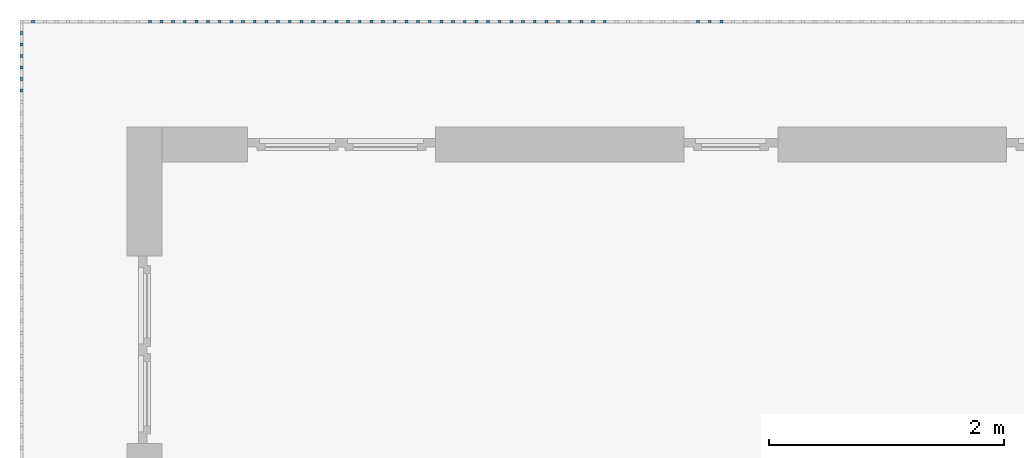
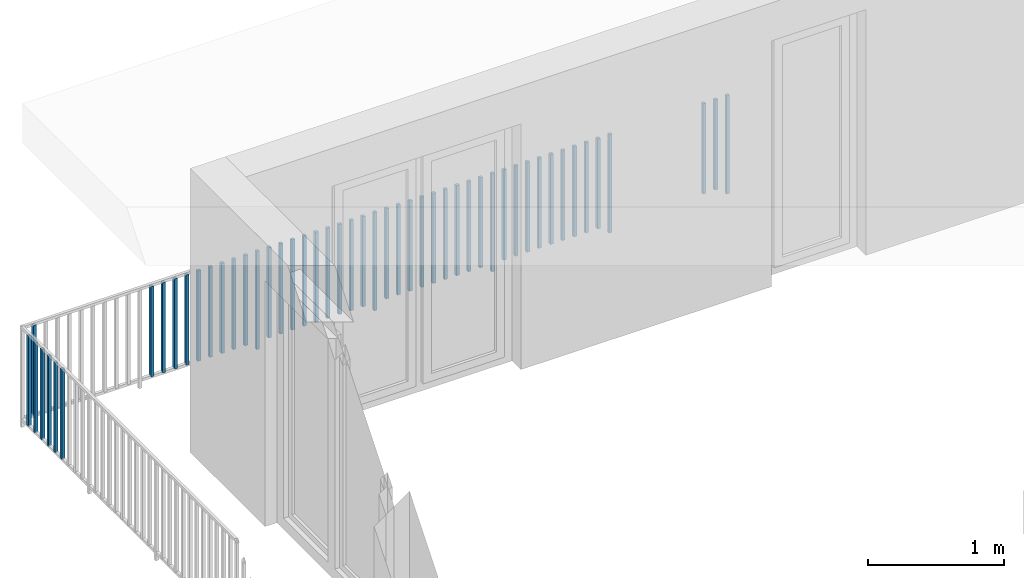
# One storey, part 42 of 48: 50 building element parts, 1 element without a shape of its own.
"""IFC4 building model written with IfcOpenShell, lengths in metres."""

import ifcopenshell
import ifcopenshell.guid

model = None  # the IFC model being written
_history = None  # IfcOwnerHistory: only IFC2X3 demands one
_inside = {}  # id of a spatial element -> (the spatial element, [elements in it])
_under = {}  # id of a project, library or spatial element -> (it, [spatial elements below it])
_declared = {}  # id of a project -> (the project, [libraries it declares])
_typed = {}  # id of a type object -> (the type object, [elements of that type])
_made_of = {}  # id of a material, layer set ... -> (it, [elements and type objects made of it])


def new_model(schema):
    """Start an empty IFC model of exactly this schema.

    Asked for "IFC4X3", IfcOpenShell would pick the latest addendum, in which some entities
    have other attributes; the version numbers below select the first issue.
    IFC2X3 requires an IfcOwnerHistory on every rooted entity: one is made here for all.
    """
    global model, _history
    if schema == "IFC4X3":
        model = ifcopenshell.file(schema_version=(4, 3, 0, 0))
    else:
        model = ifcopenshell.file(schema=schema)
    _inside.clear()
    _under.clear()
    _declared.clear()
    _typed.clear()
    _made_of.clear()
    _history = None
    if model.schema == "IFC2X3":
        org = make("IfcOrganization", Name="unknown")
        user = make(
            "IfcPersonAndOrganization",
            ThePerson=make("IfcPerson", FamilyName="unknown"),
            TheOrganization=org,
        )
        app = make(
            "IfcApplication",
            ApplicationDeveloper=org,
            Version="unknown",
            ApplicationFullName="unknown",
            ApplicationIdentifier="unknown",
        )
        _history = make(
            "IfcOwnerHistory",
            OwningUser=user,
            OwningApplication=app,
            ChangeAction="ADDED",
            CreationDate=0,
        )
    return model


def make(cls, **values):
    """One entity of the class cls with the attributes given. An attribute that is None is left unset."""
    return model.create_entity(
        cls, **{name: value for name, value in values.items() if value is not None}
    )


def entity(cls, *values):
    """Any entity or typed value of the class cls, its attributes in the order of the schema. None: left unset."""
    e = model.create_entity(cls)
    for i, value in enumerate(values):
        if value is not None:
            e[i] = value
    return e


def rooted(cls, **values):
    """An entity with a GlobalId (a new one), such as an element, a storey or a relation."""
    return make(cls, GlobalId=ifcopenshell.guid.new(), OwnerHistory=_history, **values)


def si_unit(unit_type, name, prefix=None):
    """IfcSIUnit, for example si_unit("LENGTHUNIT", "METRE", prefix="MILLI")."""
    return make("IfcSIUnit", UnitType=unit_type, Prefix=prefix, Name=name)


def converted_unit(unit_type, name, factor, base, dimensions=None, offset=None):
    """IfcConversionBasedUnit, such as the inch: factor (a typed value) times the base unit."""
    return make(
        "IfcConversionBasedUnit"
        if offset is None
        else "IfcConversionBasedUnitWithOffset",
        ConversionOffset=offset,
        Dimensions=None
        if dimensions is None
        else entity("IfcDimensionalExponents", *dimensions),
        UnitType=unit_type,
        Name=name,
        ConversionFactor=make(
            "IfcMeasureWithUnit", ValueComponent=factor, UnitComponent=base
        ),
    )


def derived_unit(unit_type, elements):
    """IfcDerivedUnit: a product of units, each with its exponent."""
    return make(
        "IfcDerivedUnit",
        Elements=[
            make("IfcDerivedUnitElement", Unit=unit, Exponent=power)
            for unit, power in elements
        ],
        UnitType=unit_type,
    )


def assignment(units):
    """IfcUnitAssignment: the units of a project."""
    return None if units is None else make("IfcUnitAssignment", Units=units)


def point(xyz):
    """IfcCartesianPoint."""
    return None if xyz is None else make("IfcCartesianPoint", Coordinates=xyz)


def direction(xyz):
    """IfcDirection."""
    return None if xyz is None else make("IfcDirection", DirectionRatios=xyz)


def frame(location, z_axis=None, x_axis=None):
    """IfcAxis2Placement3D, a coordinate frame: its origin and axes. An axis left out is left unset."""
    return make(
        "IfcAxis2Placement3D",
        Location=point(location),
        Axis=direction(z_axis),
        RefDirection=direction(x_axis),
    )


def origin_with_axes():
    """The frame at (0, 0, 0) with the z axis (0, 0, 1) and the x axis (1, 0, 0) written out."""
    return frame((0.0, 0.0, 0.0), z_axis=(0.0, 0.0, 1.0), x_axis=(1.0, 0.0, 0.0))


def place(relative_to, where):
    """IfcLocalPlacement: puts the frame where relative to a parent placement (None: the world)."""
    return make(
        "IfcLocalPlacement", PlacementRelTo=relative_to, RelativePlacement=where
    )


def context(
    kind, dimensions, precision=None, world=None, true_north=None, identifier=None
):
    """IfcGeometricRepresentationContext, for example the 3D "Model" context."""
    return make(
        "IfcGeometricRepresentationContext",
        ContextIdentifier=identifier,
        ContextType=kind,
        CoordinateSpaceDimension=dimensions,
        Precision=precision,
        WorldCoordinateSystem=world,
        TrueNorth=true_north,
    )


def subcontext(parent, identifier, kind, view, scale=None):
    """IfcGeometricRepresentationSubContext, for example "Body" below "Model"."""
    return make(
        "IfcGeometricRepresentationSubContext",
        ContextIdentifier=identifier,
        ContextType=kind,
        ParentContext=parent,
        TargetScale=scale,
        TargetView=view,
    )


def project(units=None, contexts=None):
    """IfcProject with its units and contexts."""
    return rooted(
        "IfcProject",
        Name="project",
        RepresentationContexts=contexts,
        UnitsInContext=assignment(units),
    )


def spatial(cls, under=None, at=None, **own):
    """A site, building, storey or space (cls), placed at a placement, below another one or the project."""
    s = rooted(cls, ObjectPlacement=at, **own)
    if under is not None:
        _under.setdefault(under.id(), (under, []))[1].append(s)
    return s


def point_list(points):
    """IfcCartesianPointList2D or 3D."""
    cls = (
        "IfcCartesianPointList2D" if len(points[0]) == 2 else "IfcCartesianPointList3D"
    )
    return make(cls, CoordList=points)


def polygons(points, faces, closed=None, point_numbers=None):
    """IfcPolygonalFaceSet: a face is its outer loop, then its inner loops; points numbered from 1."""
    made = []
    for loops in faces:
        if len(loops) == 1:
            made.append(make("IfcIndexedPolygonalFace", CoordIndex=loops[0]))
        else:
            made.append(
                make(
                    "IfcIndexedPolygonalFaceWithVoids",
                    CoordIndex=loops[0],
                    InnerCoordIndices=loops[1:],
                )
            )
    return make(
        "IfcPolygonalFaceSet",
        Coordinates=point_list(points),
        Closed=closed,
        Faces=made,
        PnIndex=point_numbers,
    )


def shape(context_of_items, identifier, shape_type, items):
    """IfcShapeRepresentation: the items that make up one representation, for example the "Body"."""
    return make(
        "IfcShapeRepresentation",
        ContextOfItems=context_of_items,
        RepresentationIdentifier=identifier,
        RepresentationType=shape_type,
        Items=items,
    )


def material(Name=None, Category=None):
    """IfcMaterial."""
    return make("IfcMaterial", Name=Name, Category=Category)


def made_of(thing, what):
    """Note that an element or type object is made of a material, layer set ...; save() writes the relation."""
    if what is not None:
        _made_of.setdefault(what.id(), (what, []))[1].append(thing)
    return thing


def type_object(cls, material=None, **own):
    """A type object (cls), such as IfcWallType, which elements share."""
    return made_of(rooted(cls, **own), material)


def element(
    cls,
    number,
    at=None,
    inside=None,
    cuts=None,
    type_object=None,
    material=None,
    context=None,
    identifier="Body",
    shape_type=None,
    held_by="IfcProductDefinitionShape",
    body=None,
    shapes=None,
    **own,
):
    """One element of the class cls, such as IfcWall. Its Tag is "e" and its number.

    at: its placement. inside: the storey or other place that contains it. cuts: it is an
    opening in that element (IfcRelVoidsElement). A single representation is given by context,
    identifier, shape_type and body (its items); several are given by shapes. held_by: the class
    of the entity that holds the representations. save() writes the other relations.
    """
    e = rooted(cls, Tag="e%d" % number, ObjectPlacement=at, **own)
    if body is not None:
        shapes = [shape(context, identifier, shape_type, body)]
    if shapes is not None:
        e.Representation = make(held_by, Representations=shapes)
    if inside is not None:
        _inside.setdefault(inside.id(), (inside, []))[1].append(e)
    if cuts is not None:
        rooted(
            "IfcRelVoidsElement", RelatingBuildingElement=cuts, RelatedOpeningElement=e
        )
    if type_object is not None:
        _typed.setdefault(type_object.id(), (type_object, []))[1].append(e)
    return made_of(e, material)


def aggregate(whole, parts):
    """IfcRelAggregates: a whole, such as a stair, and the parts it consists of."""
    return rooted("IfcRelAggregates", RelatingObject=whole, RelatedObjects=parts)


def save(model, path):
    """Write the relations noted so far, then the file.

    IfcRelAggregates (storeys below a building ...), IfcRelContainedInSpatialStructure (elements
    in a storey), IfcRelDefinesByType, IfcRelAssociatesMaterial and IfcRelDeclares: one each for
    every whole, place, type object, material and project.
    """
    for whole, parts in _under.values():
        aggregate(whole, parts)
    for where, things in _inside.values():
        rooted(
            "IfcRelContainedInSpatialStructure",
            RelatedElements=things,
            RelatingStructure=where,
        )
    for kind, things in _typed.values():
        rooted("IfcRelDefinesByType", RelatedObjects=things, RelatingType=kind)
    for what, things in _made_of.values():
        rooted("IfcRelAssociatesMaterial", RelatedObjects=things, RelatingMaterial=what)
    for by, libraries in _declared.values():
        rooted("IfcRelDeclares", RelatingContext=by, RelatedDefinitions=libraries)
    model.write(path)


model = new_model("IFC4")

# Units and contexts
model_context = context("Model", 3, precision=1e-05, world=origin_with_axes(), true_north=direction((0.0, 1.0)))
body_context = subcontext(model_context, "Body", "Model", "MODEL_VIEW")
ifc_project = project(units=[si_unit("LENGTHUNIT", "METRE"), si_unit("AREAUNIT", "SQUARE_METRE"), si_unit("VOLUMEUNIT", "CUBIC_METRE"), converted_unit("PLANEANGLEUNIT", "DEGREE", entity("IfcPlaneAngleMeasure", 0.0174532925199), si_unit("PLANEANGLEUNIT", "RADIAN"), dimensions=[0, 0, 0, 0, 0, 0, 0]), converted_unit("TIMEUNIT", "Year", entity("IfcTimeMeasure", 31556926.0), si_unit("TIMEUNIT", "SECOND"), dimensions=[0, 0, 1, 0, 0, 0, 0]), si_unit("MASSUNIT", "GRAM", prefix="KILO"), si_unit("THERMODYNAMICTEMPERATUREUNIT", "DEGREE_CELSIUS"), si_unit("LUMINOUSINTENSITYUNIT", "LUMEN"), si_unit("ENERGYUNIT", "JOULE", prefix="MEGA"), derived_unit("THERMALCONDUCTANCEUNIT", [(si_unit("POWERUNIT", "WATT"), 1), (si_unit("LENGTHUNIT", "METRE"), -1), (si_unit("THERMODYNAMICTEMPERATUREUNIT", "KELVIN"), -1)]), derived_unit("SPECIFICHEATCAPACITYUNIT", [(si_unit("ENERGYUNIT", "JOULE"), 1), (si_unit("MASSUNIT", "GRAM", prefix="KILO"), -1), (si_unit("THERMODYNAMICTEMPERATUREUNIT", "KELVIN"), -1)]), derived_unit("MASSDENSITYUNIT", [(si_unit("MASSUNIT", "GRAM", prefix="KILO"), 1), (si_unit("VOLUMEUNIT", "CUBIC_METRE"), -1)])], contexts=[model_context])

# Site, building, storey
site_placement = place(None, origin_with_axes())
site = spatial("IfcSite", under=ifc_project, at=site_placement, CompositionType="ELEMENT")
building_placement = place(site_placement, origin_with_axes())
building = spatial("IfcBuilding", under=site, at=building_placement, CompositionType="ELEMENT")
storey_placement = place(building_placement, frame((0.0, 0.0, 3.4), z_axis=(0.0, 0.0, 1.0), x_axis=(1.0, 0.0, 0.0)))
storey = spatial("IfcBuildingStorey", under=building, at=storey_placement, Name="1. Geschoss", CompositionType="ELEMENT", Elevation=3.4)

# Railing, building element parts
railing_type = type_object("IfcRailingType", PredefinedType="NOTDEFINED")
railing_placement = place(storey_placement, frame((10.2378006196, 9.82118776896, 0.0), z_axis=(0.0, 0.0, 1.0), x_axis=(1.0, 0.0, 0.0)))
railing = element("IfcRailing", 1, at=railing_placement, inside=storey, type_object=railing_type, PredefinedType="NOTDEFINED")
ifc_material = material()
building_element_part_1_placement = place(railing_placement, origin_with_axes())
building_element_part_1 = element("IfcBuildingElementPart", 2, at=building_element_part_1_placement, material=ifc_material, PredefinedType="NOTDEFINED", context=body_context, shape_type="Tessellation", body=[
    polygons([(-16.9238043478, 0.0125, 0.0), (-16.9238043478, -0.0125, 0.0), (-16.9238043478, -0.0125, 0.88), (-16.9238043478, 0.0125, 0.88), (-16.8988043478, 0.0125, 0.0), (-16.8988043478, -0.0125, 0.0), (-16.8988043478, -0.0125, 0.88), (-16.8988043478, 0.0125, 0.88)], [[[1, 2, 3, 4]], [[1, 5, 6, 2]], [[2, 6, 7, 3]], [[4, 3, 7, 8]], [[5, 1, 4, 8]], [[6, 5, 8, 7]]], closed=True),
])
building_element_part_2_placement = place(railing_placement, origin_with_axes())
building_element_part_2 = element("IfcBuildingElementPart", 3, at=building_element_part_2_placement, material=ifc_material, PredefinedType="NOTDEFINED", context=body_context, shape_type="Tessellation", body=[
    polygons([(-17.0232826087, 0.0125, 0.07), (-17.0232826087, -0.0125, 0.07), (-17.0232826087, -0.0125, 0.8775), (-17.0232826087, 0.0125, 0.8775), (-16.9982826087, 0.0125, 0.07), (-16.9982826087, -0.0125, 0.07), (-16.9982826087, -0.0125, 0.8775), (-16.9982826087, 0.0125, 0.8775)], [[[1, 2, 3, 4]], [[1, 5, 6, 2]], [[2, 6, 7, 3]], [[4, 3, 7, 8]], [[5, 1, 4, 8]], [[6, 5, 8, 7]]], closed=True),
])
building_element_part_3_placement = place(railing_placement, origin_with_axes())
building_element_part_3 = element("IfcBuildingElementPart", 4, at=building_element_part_3_placement, material=ifc_material, PredefinedType="NOTDEFINED", context=body_context, shape_type="Tessellation", body=[
    polygons([(-17.1227608696, 0.0125, 0.07), (-17.1227608696, -0.0125, 0.07), (-17.1227608696, -0.0125, 0.8775), (-17.1227608696, 0.0125, 0.8775), (-17.0977608696, 0.0125, 0.07), (-17.0977608696, -0.0125, 0.07), (-17.0977608696, -0.0125, 0.8775), (-17.0977608696, 0.0125, 0.8775)], [[[1, 2, 3, 4]], [[1, 5, 6, 2]], [[2, 6, 7, 3]], [[4, 3, 7, 8]], [[5, 1, 4, 8]], [[6, 5, 8, 7]]], closed=True),
])
building_element_part_4_placement = place(railing_placement, origin_with_axes())
building_element_part_4 = element("IfcBuildingElementPart", 5, at=building_element_part_4_placement, material=ifc_material, PredefinedType="NOTDEFINED", context=body_context, shape_type="Tessellation", body=[
    polygons([(-17.9185869565, 0.0125, 0.0), (-17.9185869565, -0.0125, 0.0), (-17.9185869565, -0.0125, 0.88), (-17.9185869565, 0.0125, 0.88), (-17.8935869565, 0.0125, 0.0), (-17.8935869565, -0.0125, 0.0), (-17.8935869565, -0.0125, 0.88), (-17.8935869565, 0.0125, 0.88)], [[[1, 2, 3, 4]], [[1, 5, 6, 2]], [[2, 6, 7, 3]], [[4, 3, 7, 8]], [[5, 1, 4, 8]], [[6, 5, 8, 7]]], closed=True),
])
building_element_part_5_placement = place(railing_placement, origin_with_axes())
building_element_part_5 = element("IfcBuildingElementPart", 6, at=building_element_part_5_placement, material=ifc_material, PredefinedType="NOTDEFINED", context=body_context, shape_type="Tessellation", body=[
    polygons([(-18.0180652174, 0.0125, 0.07), (-18.0180652174, -0.0125, 0.07), (-18.0180652174, -0.0125, 0.8775), (-18.0180652174, 0.0125, 0.8775), (-17.9930652174, 0.0125, 0.07), (-17.9930652174, -0.0125, 0.07), (-17.9930652174, -0.0125, 0.8775), (-17.9930652174, 0.0125, 0.8775)], [[[1, 2, 3, 4]], [[1, 5, 6, 2]], [[2, 6, 7, 3]], [[4, 3, 7, 8]], [[5, 1, 4, 8]], [[6, 5, 8, 7]]], closed=True),
])
building_element_part_6_placement = place(railing_placement, origin_with_axes())
building_element_part_6 = element("IfcBuildingElementPart", 7, at=building_element_part_6_placement, material=ifc_material, PredefinedType="NOTDEFINED", context=body_context, shape_type="Tessellation", body=[
    polygons([(-18.1175434783, 0.0125, 0.07), (-18.1175434783, -0.0125, 0.07), (-18.1175434783, -0.0125, 0.8775), (-18.1175434783, 0.0125, 0.8775), (-18.0925434783, 0.0125, 0.07), (-18.0925434783, -0.0125, 0.07), (-18.0925434783, -0.0125, 0.8775), (-18.0925434783, 0.0125, 0.8775)], [[[1, 2, 3, 4]], [[1, 5, 6, 2]], [[2, 6, 7, 3]], [[4, 3, 7, 8]], [[5, 1, 4, 8]], [[6, 5, 8, 7]]], closed=True),
])
building_element_part_7_placement = place(railing_placement, origin_with_axes())
building_element_part_7 = element("IfcBuildingElementPart", 8, at=building_element_part_7_placement, material=ifc_material, PredefinedType="NOTDEFINED", context=body_context, shape_type="Tessellation", body=[
    polygons([(-18.2170217391, 0.0125, 0.07), (-18.2170217391, -0.0125, 0.07), (-18.2170217391, -0.0125, 0.8775), (-18.2170217391, 0.0125, 0.8775), (-18.1920217391, 0.0125, 0.07), (-18.1920217391, -0.0125, 0.07), (-18.1920217391, -0.0125, 0.8775), (-18.1920217391, 0.0125, 0.8775)], [[[1, 2, 3, 4]], [[1, 5, 6, 2]], [[2, 6, 7, 3]], [[4, 3, 7, 8]], [[5, 1, 4, 8]], [[6, 5, 8, 7]]], closed=True),
])
building_element_part_8_placement = place(railing_placement, origin_with_axes())
building_element_part_8 = element("IfcBuildingElementPart", 9, at=building_element_part_8_placement, material=ifc_material, PredefinedType="NOTDEFINED", context=body_context, shape_type="Tessellation", body=[
    polygons([(-18.3165, 0.0125, 0.07), (-18.3165, -0.0125, 0.07), (-18.3165, -0.0125, 0.8775), (-18.3165, 0.0125, 0.8775), (-18.2915, 0.0125, 0.07), (-18.2915, -0.0125, 0.07), (-18.2915, -0.0125, 0.8775), (-18.2915, 0.0125, 0.8775)], [[[1, 2, 3, 4]], [[1, 5, 6, 2]], [[2, 6, 7, 3]], [[4, 3, 7, 8]], [[5, 1, 4, 8]], [[6, 5, 8, 7]]], closed=True),
])
building_element_part_9_placement = place(railing_placement, origin_with_axes())
building_element_part_9 = element("IfcBuildingElementPart", 10, at=building_element_part_9_placement, material=ifc_material, PredefinedType="NOTDEFINED", context=body_context, shape_type="Tessellation", body=[
    polygons([(-18.4159782609, 0.0125, 0.07), (-18.4159782609, -0.0125, 0.07), (-18.4159782609, -0.0125, 0.8775), (-18.4159782609, 0.0125, 0.8775), (-18.3909782609, 0.0125, 0.07), (-18.3909782609, -0.0125, 0.07), (-18.3909782609, -0.0125, 0.8775), (-18.3909782609, 0.0125, 0.8775)], [[[1, 2, 3, 4]], [[1, 5, 6, 2]], [[2, 6, 7, 3]], [[4, 3, 7, 8]], [[5, 1, 4, 8]], [[6, 5, 8, 7]]], closed=True),
])
building_element_part_10_placement = place(railing_placement, origin_with_axes())
building_element_part_10 = element("IfcBuildingElementPart", 11, at=building_element_part_10_placement, material=ifc_material, PredefinedType="NOTDEFINED", context=body_context, shape_type="Tessellation", body=[
    polygons([(-18.5154565217, 0.0125, 0.07), (-18.5154565217, -0.0125, 0.07), (-18.5154565217, -0.0125, 0.8775), (-18.5154565217, 0.0125, 0.8775), (-18.4904565217, 0.0125, 0.07), (-18.4904565217, -0.0125, 0.07), (-18.4904565217, -0.0125, 0.8775), (-18.4904565217, 0.0125, 0.8775)], [[[1, 2, 3, 4]], [[1, 5, 6, 2]], [[2, 6, 7, 3]], [[4, 3, 7, 8]], [[5, 1, 4, 8]], [[6, 5, 8, 7]]], closed=True),
])
building_element_part_11_placement = place(railing_placement, origin_with_axes())
building_element_part_11 = element("IfcBuildingElementPart", 12, at=building_element_part_11_placement, material=ifc_material, PredefinedType="NOTDEFINED", context=body_context, shape_type="Tessellation", body=[
    polygons([(-18.6149347826, 0.0125, 0.07), (-18.6149347826, -0.0125, 0.07), (-18.6149347826, -0.0125, 0.8775), (-18.6149347826, 0.0125, 0.8775), (-18.5899347826, 0.0125, 0.07), (-18.5899347826, -0.0125, 0.07), (-18.5899347826, -0.0125, 0.8775), (-18.5899347826, 0.0125, 0.8775)], [[[1, 2, 3, 4]], [[1, 5, 6, 2]], [[2, 6, 7, 3]], [[4, 3, 7, 8]], [[5, 1, 4, 8]], [[6, 5, 8, 7]]], closed=True),
])
building_element_part_12_placement = place(railing_placement, origin_with_axes())
building_element_part_12 = element("IfcBuildingElementPart", 13, at=building_element_part_12_placement, material=ifc_material, PredefinedType="NOTDEFINED", context=body_context, shape_type="Tessellation", body=[
    polygons([(-18.7144130435, 0.0125, 0.07), (-18.7144130435, -0.0125, 0.07), (-18.7144130435, -0.0125, 0.8775), (-18.7144130435, 0.0125, 0.8775), (-18.6894130435, 0.0125, 0.07), (-18.6894130435, -0.0125, 0.07), (-18.6894130435, -0.0125, 0.8775), (-18.6894130435, 0.0125, 0.8775)], [[[1, 2, 3, 4]], [[1, 5, 6, 2]], [[2, 6, 7, 3]], [[4, 3, 7, 8]], [[5, 1, 4, 8]], [[6, 5, 8, 7]]], closed=True),
])
building_element_part_13_placement = place(railing_placement, origin_with_axes())
building_element_part_13 = element("IfcBuildingElementPart", 14, at=building_element_part_13_placement, material=ifc_material, PredefinedType="NOTDEFINED", context=body_context, shape_type="Tessellation", body=[
    polygons([(-18.8138913043, 0.0125, 0.07), (-18.8138913043, -0.0125, 0.07), (-18.8138913043, -0.0125, 0.8775), (-18.8138913043, 0.0125, 0.8775), (-18.7888913043, 0.0125, 0.07), (-18.7888913043, -0.0125, 0.07), (-18.7888913043, -0.0125, 0.8775), (-18.7888913043, 0.0125, 0.8775)], [[[1, 2, 3, 4]], [[1, 5, 6, 2]], [[2, 6, 7, 3]], [[4, 3, 7, 8]], [[5, 1, 4, 8]], [[6, 5, 8, 7]]], closed=True),
])
building_element_part_14_placement = place(railing_placement, origin_with_axes())
building_element_part_14 = element("IfcBuildingElementPart", 15, at=building_element_part_14_placement, material=ifc_material, PredefinedType="NOTDEFINED", context=body_context, shape_type="Tessellation", body=[
    polygons([(-18.9133695652, 0.0125, 0.0), (-18.9133695652, -0.0125, 0.0), (-18.9133695652, -0.0125, 0.88), (-18.9133695652, 0.0125, 0.88), (-18.8883695652, 0.0125, 0.0), (-18.8883695652, -0.0125, 0.0), (-18.8883695652, -0.0125, 0.88), (-18.8883695652, 0.0125, 0.88)], [[[1, 2, 3, 4]], [[1, 5, 6, 2]], [[2, 6, 7, 3]], [[4, 3, 7, 8]], [[5, 1, 4, 8]], [[6, 5, 8, 7]]], closed=True),
])
building_element_part_15_placement = place(railing_placement, origin_with_axes())
building_element_part_15 = element("IfcBuildingElementPart", 16, at=building_element_part_15_placement, material=ifc_material, PredefinedType="NOTDEFINED", context=body_context, shape_type="Tessellation", body=[
    polygons([(-19.0128478261, 0.0125, 0.07), (-19.0128478261, -0.0125, 0.07), (-19.0128478261, -0.0125, 0.8775), (-19.0128478261, 0.0125, 0.8775), (-18.9878478261, 0.0125, 0.07), (-18.9878478261, -0.0125, 0.07), (-18.9878478261, -0.0125, 0.8775), (-18.9878478261, 0.0125, 0.8775)], [[[1, 2, 3, 4]], [[1, 5, 6, 2]], [[2, 6, 7, 3]], [[4, 3, 7, 8]], [[5, 1, 4, 8]], [[6, 5, 8, 7]]], closed=True),
])
building_element_part_16_placement = place(railing_placement, origin_with_axes())
building_element_part_16 = element("IfcBuildingElementPart", 17, at=building_element_part_16_placement, material=ifc_material, PredefinedType="NOTDEFINED", context=body_context, shape_type="Tessellation", body=[
    polygons([(-19.112326087, 0.0125, 0.07), (-19.112326087, -0.0125, 0.07), (-19.112326087, -0.0125, 0.8775), (-19.112326087, 0.0125, 0.8775), (-19.087326087, 0.0125, 0.07), (-19.087326087, -0.0125, 0.07), (-19.087326087, -0.0125, 0.8775), (-19.087326087, 0.0125, 0.8775)], [[[1, 2, 3, 4]], [[1, 5, 6, 2]], [[2, 6, 7, 3]], [[4, 3, 7, 8]], [[5, 1, 4, 8]], [[6, 5, 8, 7]]], closed=True),
])
building_element_part_17_placement = place(railing_placement, origin_with_axes())
building_element_part_17 = element("IfcBuildingElementPart", 18, at=building_element_part_17_placement, material=ifc_material, PredefinedType="NOTDEFINED", context=body_context, shape_type="Tessellation", body=[
    polygons([(-19.2118043478, 0.0125, 0.07), (-19.2118043478, -0.0125, 0.07), (-19.2118043478, -0.0125, 0.8775), (-19.2118043478, 0.0125, 0.8775), (-19.1868043478, 0.0125, 0.07), (-19.1868043478, -0.0125, 0.07), (-19.1868043478, -0.0125, 0.8775), (-19.1868043478, 0.0125, 0.8775)], [[[1, 2, 3, 4]], [[1, 5, 6, 2]], [[2, 6, 7, 3]], [[4, 3, 7, 8]], [[5, 1, 4, 8]], [[6, 5, 8, 7]]], closed=True),
])
building_element_part_18_placement = place(railing_placement, origin_with_axes())
building_element_part_18 = element("IfcBuildingElementPart", 19, at=building_element_part_18_placement, material=ifc_material, PredefinedType="NOTDEFINED", context=body_context, shape_type="Tessellation", body=[
    polygons([(-19.3112826087, 0.0125, 0.07), (-19.3112826087, -0.0125, 0.07), (-19.3112826087, -0.0125, 0.8775), (-19.3112826087, 0.0125, 0.8775), (-19.2862826087, 0.0125, 0.07), (-19.2862826087, -0.0125, 0.07), (-19.2862826087, -0.0125, 0.8775), (-19.2862826087, 0.0125, 0.8775)], [[[1, 2, 3, 4]], [[1, 5, 6, 2]], [[2, 6, 7, 3]], [[4, 3, 7, 8]], [[5, 1, 4, 8]], [[6, 5, 8, 7]]], closed=True),
])
building_element_part_19_placement = place(railing_placement, origin_with_axes())
building_element_part_19 = element("IfcBuildingElementPart", 20, at=building_element_part_19_placement, material=ifc_material, PredefinedType="NOTDEFINED", context=body_context, shape_type="Tessellation", body=[
    polygons([(-19.4107608696, 0.0125, 0.07), (-19.4107608696, -0.0125, 0.07), (-19.4107608696, -0.0125, 0.8775), (-19.4107608696, 0.0125, 0.8775), (-19.3857608696, 0.0125, 0.07), (-19.3857608696, -0.0125, 0.07), (-19.3857608696, -0.0125, 0.8775), (-19.3857608696, 0.0125, 0.8775)], [[[1, 2, 3, 4]], [[1, 5, 6, 2]], [[2, 6, 7, 3]], [[4, 3, 7, 8]], [[5, 1, 4, 8]], [[6, 5, 8, 7]]], closed=True),
])
building_element_part_20_placement = place(railing_placement, origin_with_axes())
building_element_part_20 = element("IfcBuildingElementPart", 21, at=building_element_part_20_placement, material=ifc_material, PredefinedType="NOTDEFINED", context=body_context, shape_type="Tessellation", body=[
    polygons([(-19.5102391304, 0.0125, 0.07), (-19.5102391304, -0.0125, 0.07), (-19.5102391304, -0.0125, 0.8775), (-19.5102391304, 0.0125, 0.8775), (-19.4852391304, 0.0125, 0.07), (-19.4852391304, -0.0125, 0.07), (-19.4852391304, -0.0125, 0.8775), (-19.4852391304, 0.0125, 0.8775)], [[[1, 2, 3, 4]], [[1, 5, 6, 2]], [[2, 6, 7, 3]], [[4, 3, 7, 8]], [[5, 1, 4, 8]], [[6, 5, 8, 7]]], closed=True),
])
building_element_part_21_placement = place(railing_placement, origin_with_axes())
building_element_part_21 = element("IfcBuildingElementPart", 22, at=building_element_part_21_placement, material=ifc_material, PredefinedType="NOTDEFINED", context=body_context, shape_type="Tessellation", body=[
    polygons([(-19.6097173913, 0.0125, 0.07), (-19.6097173913, -0.0125, 0.07), (-19.6097173913, -0.0125, 0.8775), (-19.6097173913, 0.0125, 0.8775), (-19.5847173913, 0.0125, 0.07), (-19.5847173913, -0.0125, 0.07), (-19.5847173913, -0.0125, 0.8775), (-19.5847173913, 0.0125, 0.8775)], [[[1, 2, 3, 4]], [[1, 5, 6, 2]], [[2, 6, 7, 3]], [[4, 3, 7, 8]], [[5, 1, 4, 8]], [[6, 5, 8, 7]]], closed=True),
])
building_element_part_22_placement = place(railing_placement, origin_with_axes())
building_element_part_22 = element("IfcBuildingElementPart", 23, at=building_element_part_22_placement, material=ifc_material, PredefinedType="NOTDEFINED", context=body_context, shape_type="Tessellation", body=[
    polygons([(-19.7091956522, 0.0125, 0.07), (-19.7091956522, -0.0125, 0.07), (-19.7091956522, -0.0125, 0.8775), (-19.7091956522, 0.0125, 0.8775), (-19.6841956522, 0.0125, 0.07), (-19.6841956522, -0.0125, 0.07), (-19.6841956522, -0.0125, 0.8775), (-19.6841956522, 0.0125, 0.8775)], [[[1, 2, 3, 4]], [[1, 5, 6, 2]], [[2, 6, 7, 3]], [[4, 3, 7, 8]], [[5, 1, 4, 8]], [[6, 5, 8, 7]]], closed=True),
])
building_element_part_23_placement = place(railing_placement, origin_with_axes())
building_element_part_23 = element("IfcBuildingElementPart", 24, at=building_element_part_23_placement, material=ifc_material, PredefinedType="NOTDEFINED", context=body_context, shape_type="Tessellation", body=[
    polygons([(-19.808673913, 0.0125, 0.07), (-19.808673913, -0.0125, 0.07), (-19.808673913, -0.0125, 0.8775), (-19.808673913, 0.0125, 0.8775), (-19.783673913, 0.0125, 0.07), (-19.783673913, -0.0125, 0.07), (-19.783673913, -0.0125, 0.8775), (-19.783673913, 0.0125, 0.8775)], [[[1, 2, 3, 4]], [[1, 5, 6, 2]], [[2, 6, 7, 3]], [[4, 3, 7, 8]], [[5, 1, 4, 8]], [[6, 5, 8, 7]]], closed=True),
])
building_element_part_24_placement = place(railing_placement, origin_with_axes())
building_element_part_24 = element("IfcBuildingElementPart", 25, at=building_element_part_24_placement, material=ifc_material, PredefinedType="NOTDEFINED", context=body_context, shape_type="Tessellation", body=[
    polygons([(-19.9081521739, 0.0125, 0.0), (-19.9081521739, -0.0125, 0.0), (-19.9081521739, -0.0125, 0.88), (-19.9081521739, 0.0125, 0.88), (-19.8831521739, 0.0125, 0.0), (-19.8831521739, -0.0125, 0.0), (-19.8831521739, -0.0125, 0.88), (-19.8831521739, 0.0125, 0.88)], [[[1, 2, 3, 4]], [[1, 5, 6, 2]], [[2, 6, 7, 3]], [[4, 3, 7, 8]], [[5, 1, 4, 8]], [[6, 5, 8, 7]]], closed=True),
])
building_element_part_25_placement = place(railing_placement, origin_with_axes())
building_element_part_25 = element("IfcBuildingElementPart", 26, at=building_element_part_25_placement, material=ifc_material, PredefinedType="NOTDEFINED", context=body_context, shape_type="Tessellation", body=[
    polygons([(-20.0076304348, 0.0125, 0.07), (-20.0076304348, -0.0125, 0.07), (-20.0076304348, -0.0125, 0.8775), (-20.0076304348, 0.0125, 0.8775), (-19.9826304348, 0.0125, 0.07), (-19.9826304348, -0.0125, 0.07), (-19.9826304348, -0.0125, 0.8775), (-19.9826304348, 0.0125, 0.8775)], [[[1, 2, 3, 4]], [[1, 5, 6, 2]], [[2, 6, 7, 3]], [[4, 3, 7, 8]], [[5, 1, 4, 8]], [[6, 5, 8, 7]]], closed=True),
])
building_element_part_26_placement = place(railing_placement, origin_with_axes())
building_element_part_26 = element("IfcBuildingElementPart", 27, at=building_element_part_26_placement, material=ifc_material, PredefinedType="NOTDEFINED", context=body_context, shape_type="Tessellation", body=[
    polygons([(-20.1071086957, 0.0125, 0.07), (-20.1071086957, -0.0125, 0.07), (-20.1071086957, -0.0125, 0.8775), (-20.1071086957, 0.0125, 0.8775), (-20.0821086957, 0.0125, 0.07), (-20.0821086957, -0.0125, 0.07), (-20.0821086957, -0.0125, 0.8775), (-20.0821086957, 0.0125, 0.8775)], [[[1, 2, 3, 4]], [[1, 5, 6, 2]], [[2, 6, 7, 3]], [[4, 3, 7, 8]], [[5, 1, 4, 8]], [[6, 5, 8, 7]]], closed=True),
])
building_element_part_27_placement = place(railing_placement, origin_with_axes())
building_element_part_27 = element("IfcBuildingElementPart", 28, at=building_element_part_27_placement, material=ifc_material, PredefinedType="NOTDEFINED", context=body_context, shape_type="Tessellation", body=[
    polygons([(-20.2065869565, 0.0125, 0.07), (-20.2065869565, -0.0125, 0.07), (-20.2065869565, -0.0125, 0.8775), (-20.2065869565, 0.0125, 0.8775), (-20.1815869565, 0.0125, 0.07), (-20.1815869565, -0.0125, 0.07), (-20.1815869565, -0.0125, 0.8775), (-20.1815869565, 0.0125, 0.8775)], [[[1, 2, 3, 4]], [[1, 5, 6, 2]], [[2, 6, 7, 3]], [[4, 3, 7, 8]], [[5, 1, 4, 8]], [[6, 5, 8, 7]]], closed=True),
])
building_element_part_28_placement = place(railing_placement, origin_with_axes())
building_element_part_28 = element("IfcBuildingElementPart", 29, at=building_element_part_28_placement, material=ifc_material, PredefinedType="NOTDEFINED", context=body_context, shape_type="Tessellation", body=[
    polygons([(-20.3060652174, 0.0125, 0.07), (-20.3060652174, -0.0125, 0.07), (-20.3060652174, -0.0125, 0.8775), (-20.3060652174, 0.0125, 0.8775), (-20.2810652174, 0.0125, 0.07), (-20.2810652174, -0.0125, 0.07), (-20.2810652174, -0.0125, 0.8775), (-20.2810652174, 0.0125, 0.8775)], [[[1, 2, 3, 4]], [[1, 5, 6, 2]], [[2, 6, 7, 3]], [[4, 3, 7, 8]], [[5, 1, 4, 8]], [[6, 5, 8, 7]]], closed=True),
])
building_element_part_29_placement = place(railing_placement, origin_with_axes())
building_element_part_29 = element("IfcBuildingElementPart", 30, at=building_element_part_29_placement, material=ifc_material, PredefinedType="NOTDEFINED", context=body_context, shape_type="Tessellation", body=[
    polygons([(-20.4055434783, 0.0125, 0.07), (-20.4055434783, -0.0125, 0.07), (-20.4055434783, -0.0125, 0.8775), (-20.4055434783, 0.0125, 0.8775), (-20.3805434783, 0.0125, 0.07), (-20.3805434783, -0.0125, 0.07), (-20.3805434783, -0.0125, 0.8775), (-20.3805434783, 0.0125, 0.8775)], [[[1, 2, 3, 4]], [[1, 5, 6, 2]], [[2, 6, 7, 3]], [[4, 3, 7, 8]], [[5, 1, 4, 8]], [[6, 5, 8, 7]]], closed=True),
])
building_element_part_30_placement = place(railing_placement, origin_with_axes())
building_element_part_30 = element("IfcBuildingElementPart", 31, at=building_element_part_30_placement, material=ifc_material, PredefinedType="NOTDEFINED", context=body_context, shape_type="Tessellation", body=[
    polygons([(-20.5050217391, 0.0125, 0.07), (-20.5050217391, -0.0125, 0.07), (-20.5050217391, -0.0125, 0.8775), (-20.5050217391, 0.0125, 0.8775), (-20.4800217391, 0.0125, 0.07), (-20.4800217391, -0.0125, 0.07), (-20.4800217391, -0.0125, 0.8775), (-20.4800217391, 0.0125, 0.8775)], [[[1, 2, 3, 4]], [[1, 5, 6, 2]], [[2, 6, 7, 3]], [[4, 3, 7, 8]], [[5, 1, 4, 8]], [[6, 5, 8, 7]]], closed=True),
])
building_element_part_31_placement = place(railing_placement, origin_with_axes())
building_element_part_31 = element("IfcBuildingElementPart", 32, at=building_element_part_31_placement, material=ifc_material, PredefinedType="NOTDEFINED", context=body_context, shape_type="Tessellation", body=[
    polygons([(-20.6045, 0.0125, 0.07), (-20.6045, -0.0125, 0.07), (-20.6045, -0.0125, 0.8775), (-20.6045, 0.0125, 0.8775), (-20.5795, 0.0125, 0.07), (-20.5795, -0.0125, 0.07), (-20.5795, -0.0125, 0.8775), (-20.5795, 0.0125, 0.8775)], [[[1, 2, 3, 4]], [[1, 5, 6, 2]], [[2, 6, 7, 3]], [[4, 3, 7, 8]], [[5, 1, 4, 8]], [[6, 5, 8, 7]]], closed=True),
])
building_element_part_32_placement = place(railing_placement, origin_with_axes())
building_element_part_32 = element("IfcBuildingElementPart", 33, at=building_element_part_32_placement, material=ifc_material, PredefinedType="NOTDEFINED", context=body_context, shape_type="Tessellation", body=[
    polygons([(-20.7039782609, 0.0125, 0.07), (-20.7039782609, -0.0125, 0.07), (-20.7039782609, -0.0125, 0.8775), (-20.7039782609, 0.0125, 0.8775), (-20.6789782609, 0.0125, 0.07), (-20.6789782609, -0.0125, 0.07), (-20.6789782609, -0.0125, 0.8775), (-20.6789782609, 0.0125, 0.8775)], [[[1, 2, 3, 4]], [[1, 5, 6, 2]], [[2, 6, 7, 3]], [[4, 3, 7, 8]], [[5, 1, 4, 8]], [[6, 5, 8, 7]]], closed=True),
])
building_element_part_33_placement = place(railing_placement, origin_with_axes())
building_element_part_33 = element("IfcBuildingElementPart", 34, at=building_element_part_33_placement, material=ifc_material, PredefinedType="NOTDEFINED", context=body_context, shape_type="Tessellation", body=[
    polygons([(-20.8034565217, 0.0125, 0.07), (-20.8034565217, -0.0125, 0.07), (-20.8034565217, -0.0125, 0.8775), (-20.8034565217, 0.0125, 0.8775), (-20.7784565217, 0.0125, 0.07), (-20.7784565217, -0.0125, 0.07), (-20.7784565217, -0.0125, 0.8775), (-20.7784565217, 0.0125, 0.8775)], [[[1, 2, 3, 4]], [[1, 5, 6, 2]], [[2, 6, 7, 3]], [[4, 3, 7, 8]], [[5, 1, 4, 8]], [[6, 5, 8, 7]]], closed=True),
])
building_element_part_34_placement = place(railing_placement, origin_with_axes())
building_element_part_34 = element("IfcBuildingElementPart", 35, at=building_element_part_34_placement, material=ifc_material, PredefinedType="NOTDEFINED", context=body_context, shape_type="Tessellation", body=[
    polygons([(-20.9029347826, 0.0125, 0.0), (-20.9029347826, -0.0125, 0.0), (-20.9029347826, -0.0125, 0.88), (-20.9029347826, 0.0125, 0.88), (-20.8779347826, 0.0125, 0.0), (-20.8779347826, -0.0125, 0.0), (-20.8779347826, -0.0125, 0.88), (-20.8779347826, 0.0125, 0.88)], [[[1, 2, 3, 4]], [[1, 5, 6, 2]], [[2, 6, 7, 3]], [[4, 3, 7, 8]], [[5, 1, 4, 8]], [[6, 5, 8, 7]]], closed=True),
])
building_element_part_35_placement = place(railing_placement, origin_with_axes())
building_element_part_35 = element("IfcBuildingElementPart", 36, at=building_element_part_35_placement, material=ifc_material, PredefinedType="NOTDEFINED", context=body_context, shape_type="Tessellation", body=[
    polygons([(-21.0024130435, 0.0125, 0.07), (-21.0024130435, -0.0125, 0.07), (-21.0024130435, -0.0125, 0.8775), (-21.0024130435, 0.0125, 0.8775), (-20.9774130435, 0.0125, 0.07), (-20.9774130435, -0.0125, 0.07), (-20.9774130435, -0.0125, 0.8775), (-20.9774130435, 0.0125, 0.8775)], [[[1, 2, 3, 4]], [[1, 5, 6, 2]], [[2, 6, 7, 3]], [[4, 3, 7, 8]], [[5, 1, 4, 8]], [[6, 5, 8, 7]]], closed=True),
])
building_element_part_36_placement = place(railing_placement, origin_with_axes())
building_element_part_36 = element("IfcBuildingElementPart", 37, at=building_element_part_36_placement, material=ifc_material, PredefinedType="NOTDEFINED", context=body_context, shape_type="Tessellation", body=[
    polygons([(-21.1018913043, 0.0125, 0.07), (-21.1018913043, -0.0125, 0.07), (-21.1018913043, -0.0125, 0.8775), (-21.1018913043, 0.0125, 0.8775), (-21.0768913043, 0.0125, 0.07), (-21.0768913043, -0.0125, 0.07), (-21.0768913043, -0.0125, 0.8775), (-21.0768913043, 0.0125, 0.8775)], [[[1, 2, 3, 4]], [[1, 5, 6, 2]], [[2, 6, 7, 3]], [[4, 3, 7, 8]], [[5, 1, 4, 8]], [[6, 5, 8, 7]]], closed=True),
])
building_element_part_37_placement = place(railing_placement, origin_with_axes())
building_element_part_37 = element("IfcBuildingElementPart", 38, at=building_element_part_37_placement, material=ifc_material, PredefinedType="NOTDEFINED", context=body_context, shape_type="Tessellation", body=[
    polygons([(-21.2013695652, 0.0125, 0.07), (-21.2013695652, -0.0125, 0.07), (-21.2013695652, -0.0125, 0.8775), (-21.2013695652, 0.0125, 0.8775), (-21.1763695652, 0.0125, 0.07), (-21.1763695652, -0.0125, 0.07), (-21.1763695652, -0.0125, 0.8775), (-21.1763695652, 0.0125, 0.8775)], [[[1, 2, 3, 4]], [[1, 5, 6, 2]], [[2, 6, 7, 3]], [[4, 3, 7, 8]], [[5, 1, 4, 8]], [[6, 5, 8, 7]]], closed=True),
])
building_element_part_38_placement = place(railing_placement, origin_with_axes())
building_element_part_38 = element("IfcBuildingElementPart", 39, at=building_element_part_38_placement, material=ifc_material, PredefinedType="NOTDEFINED", context=body_context, shape_type="Tessellation", body=[
    polygons([(-21.3008478261, 0.0125, 0.07), (-21.3008478261, -0.0125, 0.07), (-21.3008478261, -0.0125, 0.8775), (-21.3008478261, 0.0125, 0.8775), (-21.2758478261, 0.0125, 0.07), (-21.2758478261, -0.0125, 0.07), (-21.2758478261, -0.0125, 0.8775), (-21.2758478261, 0.0125, 0.8775)], [[[1, 2, 3, 4]], [[1, 5, 6, 2]], [[2, 6, 7, 3]], [[4, 3, 7, 8]], [[5, 1, 4, 8]], [[6, 5, 8, 7]]], closed=True),
])
building_element_part_39_placement = place(railing_placement, origin_with_axes())
building_element_part_39 = element("IfcBuildingElementPart", 40, at=building_element_part_39_placement, material=ifc_material, PredefinedType="NOTDEFINED", context=body_context, shape_type="Tessellation", body=[
    polygons([(-21.400326087, 0.0125, 0.07), (-21.400326087, -0.0125, 0.07), (-21.400326087, -0.0125, 0.8775), (-21.400326087, 0.0125, 0.8775), (-21.375326087, 0.0125, 0.07), (-21.375326087, -0.0125, 0.07), (-21.375326087, -0.0125, 0.8775), (-21.375326087, 0.0125, 0.8775)], [[[1, 2, 3, 4]], [[1, 5, 6, 2]], [[2, 6, 7, 3]], [[4, 3, 7, 8]], [[5, 1, 4, 8]], [[6, 5, 8, 7]]], closed=True),
])
building_element_part_40_placement = place(railing_placement, origin_with_axes())
building_element_part_40 = element("IfcBuildingElementPart", 41, at=building_element_part_40_placement, material=ifc_material, PredefinedType="NOTDEFINED", context=body_context, shape_type="Tessellation", body=[
    polygons([(-21.4998043478, 0.0125, 0.07), (-21.4998043478, -0.0125, 0.07), (-21.4998043478, -0.0125, 0.8775), (-21.4998043478, 0.0125, 0.8775), (-21.4748043478, 0.0125, 0.07), (-21.4748043478, -0.0125, 0.07), (-21.4748043478, -0.0125, 0.8775), (-21.4748043478, 0.0125, 0.8775)], [[[1, 2, 3, 4]], [[1, 5, 6, 2]], [[2, 6, 7, 3]], [[4, 3, 7, 8]], [[5, 1, 4, 8]], [[6, 5, 8, 7]]], closed=True),
])
building_element_part_41_placement = place(railing_placement, origin_with_axes())
building_element_part_41 = element("IfcBuildingElementPart", 42, at=building_element_part_41_placement, material=ifc_material, PredefinedType="NOTDEFINED", context=body_context, shape_type="Tessellation", body=[
    polygons([(-21.5992826087, 0.0125, 0.07), (-21.5992826087, -0.0125, 0.07), (-21.5992826087, -0.0125, 0.8775), (-21.5992826087, 0.0125, 0.8775), (-21.5742826087, 0.0125, 0.07), (-21.5742826087, -0.0125, 0.07), (-21.5742826087, -0.0125, 0.8775), (-21.5742826087, 0.0125, 0.8775)], [[[1, 2, 3, 4]], [[1, 5, 6, 2]], [[2, 6, 7, 3]], [[4, 3, 7, 8]], [[5, 1, 4, 8]], [[6, 5, 8, 7]]], closed=True),
])
building_element_part_42_placement = place(railing_placement, origin_with_axes())
building_element_part_42 = element("IfcBuildingElementPart", 43, at=building_element_part_42_placement, material=ifc_material, PredefinedType="NOTDEFINED", context=body_context, shape_type="Tessellation", body=[
    polygons([(-21.6987608696, 0.0125, 0.07), (-21.6987608696, -0.0125, 0.07), (-21.6987608696, -0.0125, 0.8775), (-21.6987608696, 0.0125, 0.8775), (-21.6737608696, 0.0125, 0.07), (-21.6737608696, -0.0125, 0.07), (-21.6737608696, -0.0125, 0.8775), (-21.6737608696, 0.0125, 0.8775)], [[[1, 2, 3, 4]], [[1, 5, 6, 2]], [[2, 6, 7, 3]], [[4, 3, 7, 8]], [[5, 1, 4, 8]], [[6, 5, 8, 7]]], closed=True),
])
building_element_part_43_placement = place(railing_placement, origin_with_axes())
building_element_part_43 = element("IfcBuildingElementPart", 44, at=building_element_part_43_placement, material=ifc_material, PredefinedType="NOTDEFINED", context=body_context, shape_type="Tessellation", body=[
    polygons([(-21.7982391304, 0.0125, 0.07), (-21.7982391304, -0.0125, 0.07), (-21.7982391304, -0.0125, 0.8775), (-21.7982391304, 0.0125, 0.8775), (-21.7732391304, 0.0125, 0.07), (-21.7732391304, -0.0125, 0.07), (-21.7732391304, -0.0125, 0.8775), (-21.7732391304, 0.0125, 0.8775)], [[[1, 2, 3, 4]], [[1, 5, 6, 2]], [[2, 6, 7, 3]], [[4, 3, 7, 8]], [[5, 1, 4, 8]], [[6, 5, 8, 7]]], closed=True),
])
building_element_part_44_placement = place(railing_placement, origin_with_axes())
building_element_part_44 = element("IfcBuildingElementPart", 45, at=building_element_part_44_placement, material=ifc_material, PredefinedType="NOTDEFINED", context=body_context, shape_type="Tessellation", body=[
    polygons([(-22.7930217391, 0.0125, 0.07), (-22.7930217391, -0.0125, 0.07), (-22.7930217391, -0.0125, 0.8775), (-22.7930217391, 0.0125, 0.8775), (-22.7680217391, 0.0125, 0.07), (-22.7680217391, -0.0125, 0.07), (-22.7680217391, -0.0125, 0.8775), (-22.7680217391, 0.0125, 0.8775)], [[[1, 2, 3, 4]], [[1, 5, 6, 2]], [[2, 6, 7, 3]], [[4, 3, 7, 8]], [[5, 1, 4, 8]], [[6, 5, 8, 7]]], closed=True),
])
building_element_part_45_placement = place(railing_placement, origin_with_axes())
building_element_part_45 = element("IfcBuildingElementPart", 46, at=building_element_part_45_placement, material=ifc_material, PredefinedType="NOTDEFINED", context=body_context, shape_type="Tessellation", body=[
    polygons([(-22.8925, -0.110833333333, 0.07), (-22.8675, -0.110833333333, 0.07), (-22.8675, -0.110833333333, 0.8775), (-22.8925, -0.110833333333, 0.8775), (-22.8925, -0.0858333333333, 0.07), (-22.8675, -0.0858333333333, 0.07), (-22.8675, -0.0858333333333, 0.8775), (-22.8925, -0.0858333333333, 0.8775)], [[[1, 2, 3, 4]], [[1, 5, 6, 2]], [[2, 6, 7, 3]], [[4, 3, 7, 8]], [[5, 1, 4, 8]], [[6, 5, 8, 7]]], closed=True),
])
building_element_part_46_placement = place(railing_placement, origin_with_axes())
building_element_part_46 = element("IfcBuildingElementPart", 47, at=building_element_part_46_placement, material=ifc_material, PredefinedType="NOTDEFINED", context=body_context, shape_type="Tessellation", body=[
    polygons([(-22.8925, -0.209166666667, 0.07), (-22.8675, -0.209166666667, 0.07), (-22.8675, -0.209166666667, 0.8775), (-22.8925, -0.209166666667, 0.8775), (-22.8925, -0.184166666667, 0.07), (-22.8675, -0.184166666667, 0.07), (-22.8675, -0.184166666667, 0.8775), (-22.8925, -0.184166666667, 0.8775)], [[[1, 2, 3, 4]], [[1, 5, 6, 2]], [[2, 6, 7, 3]], [[4, 3, 7, 8]], [[5, 1, 4, 8]], [[6, 5, 8, 7]]], closed=True),
])
building_element_part_47_placement = place(railing_placement, origin_with_axes())
building_element_part_47 = element("IfcBuildingElementPart", 48, at=building_element_part_47_placement, material=ifc_material, PredefinedType="NOTDEFINED", context=body_context, shape_type="Tessellation", body=[
    polygons([(-22.8925, -0.3075, 0.07), (-22.8675, -0.3075, 0.07), (-22.8675, -0.3075, 0.8775), (-22.8925, -0.3075, 0.8775), (-22.8925, -0.2825, 0.07), (-22.8675, -0.2825, 0.07), (-22.8675, -0.2825, 0.8775), (-22.8925, -0.2825, 0.8775)], [[[1, 2, 3, 4]], [[1, 5, 6, 2]], [[2, 6, 7, 3]], [[4, 3, 7, 8]], [[5, 1, 4, 8]], [[6, 5, 8, 7]]], closed=True),
])
building_element_part_48_placement = place(railing_placement, origin_with_axes())
building_element_part_48 = element("IfcBuildingElementPart", 49, at=building_element_part_48_placement, material=ifc_material, PredefinedType="NOTDEFINED", context=body_context, shape_type="Tessellation", body=[
    polygons([(-22.8925, -0.405833333333, 0.07), (-22.8675, -0.405833333333, 0.07), (-22.8675, -0.405833333333, 0.8775), (-22.8925, -0.405833333333, 0.8775), (-22.8925, -0.380833333333, 0.07), (-22.8675, -0.380833333333, 0.07), (-22.8675, -0.380833333333, 0.8775), (-22.8925, -0.380833333333, 0.8775)], [[[1, 2, 3, 4]], [[1, 5, 6, 2]], [[2, 6, 7, 3]], [[4, 3, 7, 8]], [[5, 1, 4, 8]], [[6, 5, 8, 7]]], closed=True),
])
building_element_part_49_placement = place(railing_placement, origin_with_axes())
building_element_part_49 = element("IfcBuildingElementPart", 50, at=building_element_part_49_placement, material=ifc_material, PredefinedType="NOTDEFINED", context=body_context, shape_type="Tessellation", body=[
    polygons([(-22.8925, -0.504166666667, 0.07), (-22.8675, -0.504166666667, 0.07), (-22.8675, -0.504166666667, 0.8775), (-22.8925, -0.504166666667, 0.8775), (-22.8925, -0.479166666667, 0.07), (-22.8675, -0.479166666667, 0.07), (-22.8675, -0.479166666667, 0.8775), (-22.8925, -0.479166666667, 0.8775)], [[[1, 2, 3, 4]], [[1, 5, 6, 2]], [[2, 6, 7, 3]], [[4, 3, 7, 8]], [[5, 1, 4, 8]], [[6, 5, 8, 7]]], closed=True),
])
building_element_part_50_placement = place(railing_placement, origin_with_axes())
building_element_part_50 = element("IfcBuildingElementPart", 51, at=building_element_part_50_placement, material=ifc_material, PredefinedType="NOTDEFINED", context=body_context, shape_type="Tessellation", body=[
    polygons([(-22.8925, -0.6025, 0.07), (-22.8675, -0.6025, 0.07), (-22.8675, -0.6025, 0.8775), (-22.8925, -0.6025, 0.8775), (-22.8925, -0.5775, 0.07), (-22.8675, -0.5775, 0.07), (-22.8675, -0.5775, 0.8775), (-22.8925, -0.5775, 0.8775)], [[[1, 2, 3, 4]], [[1, 5, 6, 2]], [[2, 6, 7, 3]], [[4, 3, 7, 8]], [[5, 1, 4, 8]], [[6, 5, 8, 7]]], closed=True),
])
aggregate(railing, [building_element_part_1, building_element_part_2, building_element_part_3, building_element_part_4, building_element_part_5, building_element_part_6, building_element_part_7, building_element_part_8, building_element_part_9, building_element_part_10, building_element_part_11, building_element_part_12, building_element_part_13, building_element_part_14, building_element_part_15, building_element_part_16, building_element_part_17, building_element_part_18, building_element_part_19, building_element_part_20, building_element_part_21, building_element_part_22, building_element_part_23, building_element_part_24, building_element_part_25, building_element_part_26, building_element_part_27, building_element_part_28, building_element_part_29, building_element_part_30, building_element_part_31, building_element_part_32, building_element_part_33, building_element_part_34, building_element_part_35, building_element_part_36, building_element_part_37, building_element_part_38, building_element_part_39, building_element_part_40, building_element_part_41, building_element_part_42, building_element_part_43, building_element_part_44, building_element_part_45, building_element_part_46, building_element_part_47, building_element_part_48, building_element_part_49, building_element_part_50])

save(model, "model.ifc")
